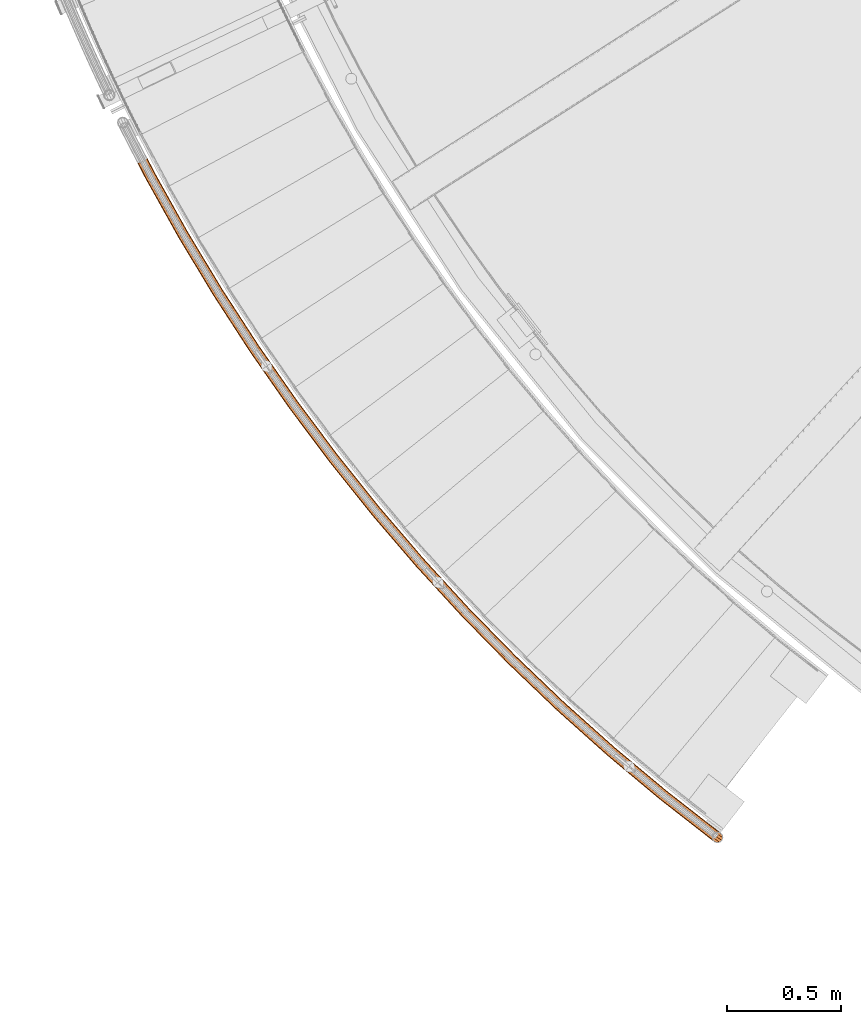
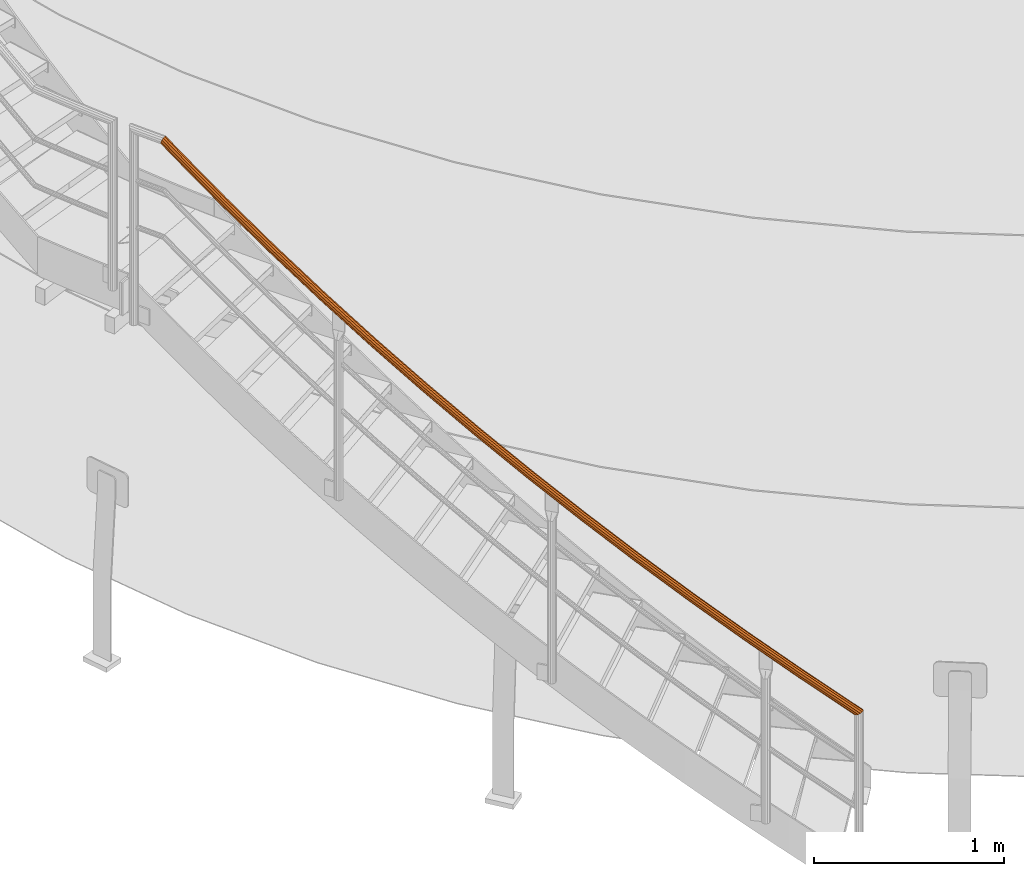
# One storey, part 5 of 126: 1 proxy.
"""IFC2X3 building model written with IfcOpenShell, lengths in millimetres."""

from ifc_helpers import new_model, si_unit, origin, origin_with_axes, place, context, project, spatial, faceted_brep, material, element, save


model = new_model("IFC2X3")

# Units and contexts
context_of_model_1 = context(None, 3, precision=0.1, world=origin())
context_of_model_2 = context(None, 3, precision=0.1, world=origin())
ifc_project = project(units=[si_unit("LENGTHUNIT", "METRE", prefix="MILLI"), si_unit("AREAUNIT", "SQUARE_METRE", prefix="CENTI"), si_unit("VOLUMEUNIT", "CUBIC_METRE", prefix="CENTI"), si_unit("MASSUNIT", "GRAM", prefix="KILO")], contexts=[context_of_model_1, context_of_model_2])

# Site, building, storey
site_placement = place(None, origin_with_axes())
site = spatial("IfcSite", under=ifc_project, at=site_placement, CompositionType="ELEMENT")
building_placement = place(site_placement, origin_with_axes())
building = spatial("IfcBuilding", under=site, at=building_placement, CompositionType="ELEMENT")
storey_placement = place(building_placement, origin_with_axes())
storey = spatial("IfcBuildingStorey", under=building, at=storey_placement, CompositionType="ELEMENT")

# Proxy
ifc_material = material(Name="S235JRG2")
proxy_placement = place(storey_placement, origin_with_axes())
element("IfcBuildingElementProxy", 1, at=proxy_placement, inside=storey, material=ifc_material, Name="HANDLAUF", context=context_of_model_2, shape_type="Brep", body=[
    faceted_brep([(2674.3558, 922.9997, 1115.3389), (2665.639, 914.408, 1112.789), (2681.7253, 902.7135, 1098.7718), (2691.5754, 910.4813, 1100.3342), (2656.2421, 910.3109, 1105.6336), (2669.3052, 900.8141, 1094.2507), (2648.6828, 911.8062, 1095.7899), (2657.6431, 905.2923, 1087.9822), (2644.9868, 918.4934, 1085.8956), (2649.8637, 914.9479, 1081.646), (2646.1442, 928.5804, 1078.6018), (2648.0516, 927.1938, 1076.9398), (2651.8451, 939.3647, 1075.863), (2652.6923, 938.7488, 1075.1247), (2660.5618, 947.9564, 1078.4128), (2662.5423, 946.5166, 1076.6871), (2669.9588, 952.0535, 1085.5683), (2674.9624, 948.4159, 1081.2082), (2677.518, 950.5581, 1095.4119), (2686.6246, 943.9378, 1087.4767), (2681.2141, 943.871, 1105.3062), (2694.4039, 934.2822, 1093.8129), (2680.0566, 933.7839, 1112.6), (2696.2161, 922.0362, 1098.5191), (2673.1906, 923.8467, 1113.2956), (2678.3013, 933.5146, 1110.8403), (2693.7231, 922.3032, 1097.4022), (2689.5628, 911.9444, 1099.0293), (2679.339, 942.5575, 1104.3015), (2692.0985, 933.2814, 1093.1832), (2676.0255, 948.5523, 1095.4315), (2685.1245, 941.9375, 1087.5029), (2669.2488, 949.8929, 1086.6068), (2674.6696, 945.952, 1081.8833), (2660.8246, 946.2199, 1080.1922), (2663.5352, 944.2493, 1077.8302), (2653.0103, 938.5176, 1077.9062), (2654.7049, 937.2857, 1076.4296), (2647.8995, 928.8498, 1080.3616), (2650.5446, 926.9269, 1078.0568), (2646.8619, 919.8069, 1086.9003), (2652.1691, 915.9486, 1082.2757), (2650.1753, 913.812, 1095.7704), (2659.1432, 907.2925, 1087.956), (2656.9521, 912.4715, 1104.595), (2669.5981, 903.278, 1093.5756), (2665.3762, 916.1444, 1111.0097), (2680.7324, 904.9807, 1097.6287), (2441.9465, 1104.063, 1322.9856), (2432.949, 1095.7658, 1320.4357), (2423.4211, 1091.9834, 1313.2801), (2415.9158, 1093.7294, 1303.4363), (2412.4441, 1100.5357, 1293.5421), (2413.9362, 1110.5786, 1286.2485), (2419.9921, 1121.1671, 1283.5097), (2428.9893, 1129.4641, 1286.0595), (2438.517, 1133.2466, 1293.2148), (2446.0224, 1131.501, 1303.0583), (2449.4944, 1124.6949, 1312.9527), (2448.0025, 1114.6519, 1320.2467), (2440.8101, 1104.9483, 1320.9424), (2446.2392, 1114.441, 1318.4869), (2447.5767, 1123.4443, 1311.9481), (2444.4641, 1129.5459, 1303.078), (2437.7357, 1131.1108, 1294.2534), (2429.1942, 1127.7199, 1287.8388), (2421.1285, 1120.2818, 1285.553), (2415.6994, 1110.7894, 1288.0083), (2414.3619, 1101.7862, 1294.5468), (2417.4742, 1095.6844, 1303.4168), (2424.2025, 1094.1192, 1312.2415), (2432.7441, 1097.51, 1318.6564), (2215.6828, 1292.7499, 1530.6324), (2206.4145, 1284.7563, 1528.0824), (2196.7662, 1281.2927, 1520.9268), (2189.3231, 1283.2871, 1511.0831), (2186.0795, 1290.205, 1501.1888), (2187.9045, 1300.1928, 1493.8952), (2194.3089, 1310.5741, 1491.1565), (2203.5768, 1318.5676, 1493.7063), (2213.225, 1322.0313, 1500.8615), (2220.6683, 1320.0373, 1510.7051), (2223.9121, 1313.1195, 1520.5995), (2222.0874, 1303.1316, 1527.8934), (2214.5765, 1293.6725, 1528.5891), (2220.318, 1302.9795, 1526.1337), (2221.9539, 1311.9334, 1519.5948), (2219.0459, 1318.135, 1510.7247), (2212.3731, 1319.9227, 1501.9001), (2203.7238, 1316.8175, 1495.4856), (2195.4152, 1309.6515, 1493.1997), (2189.6738, 1300.3448, 1495.655), (2188.0377, 1291.391, 1502.1936), (2190.9455, 1285.1892, 1511.0636), (2197.6181, 1283.4013, 1519.8883), (2206.2677, 1286.5064, 1526.3031), (1995.8146, 1488.852, 1738.2791), (1986.2858, 1481.1707, 1735.7291), (1976.5277, 1478.0297, 1728.5736), (1969.155, 1480.2703, 1718.7298), (1966.1431, 1487.2923, 1708.8356), (1968.299, 1497.2138, 1701.542), (1975.0449, 1507.3766, 1698.8032), (1984.5734, 1515.0576, 1701.353), (1994.3313, 1518.1989, 1708.5083), (2001.7042, 1515.9585, 1718.3518), (2004.7164, 1508.9368, 1728.2462), (2002.5607, 1499.0151, 1735.5402), (1994.7396, 1489.8108, 1736.2359), (2000.7873, 1498.9218, 1733.7804), (2002.7198, 1507.8164, 1727.2416), (2000.0195, 1514.1113, 1718.3715), (1993.4098, 1516.1197, 1709.5469), (1984.662, 1513.3037, 1703.1323), (1976.12, 1506.4178, 1700.8465), (1970.0724, 1497.307, 1703.3017), (1968.1397, 1488.4125, 1709.8403), (1970.8398, 1482.1175, 1718.7103), (1977.4493, 1480.1088, 1727.535), (1986.1972, 1482.9247, 1733.9499), (1782.5849, 1692.1525, 1945.9259), (1772.8061, 1684.7921, 1943.3759), (1762.949, 1681.9771, 1936.2203), (1755.6548, 1684.4615, 1926.3765), (1752.8779, 1691.5797, 1916.4823), (1755.3624, 1701.4241, 1909.1887), (1762.4423, 1711.3571, 1906.4499), (1772.2207, 1718.7172, 1908.9998), (1782.0777, 1721.5324, 1916.155), (1789.372, 1719.0483, 1925.9986), (1792.1492, 1711.9304, 1935.893), (1789.665, 1702.0858, 1943.1869), (1781.5423, 1693.1465, 1943.8826), (1787.8894, 1702.0515, 1941.4272), (1790.1165, 1710.877, 1934.8883), (1787.6268, 1717.2581, 1926.0182), (1781.0876, 1719.4851, 1917.1936), (1772.251, 1716.9613, 1910.7791), (1763.4849, 1710.3631, 1908.4932), (1757.1378, 1701.4583, 1910.9485), (1754.9106, 1692.633, 1917.4871), (1757.4, 1686.2517, 1926.3571), (1763.9391, 1684.0245, 1935.1818), (1772.7758, 1686.5481, 1941.5966), (1576.2291, 1902.4269, 2153.5726), (1566.2111, 1895.3956, 2151.0226), (1556.2659, 1892.9097, 2143.867), (1549.0583, 1895.6352, 2134.0233), (1546.5196, 1902.8416, 2124.1291), (1549.3298, 1912.5981, 2116.8355), (1556.7359, 1922.2903, 2114.0967), (1566.7535, 1929.3214, 2116.6465), (1576.6986, 1931.8075, 2123.8018), (1583.9063, 1929.0823, 2133.6453), (1586.4454, 1921.876, 2143.5397), (1583.6354, 1912.1194, 2150.8336), (1575.2202, 1903.455, 2151.5293), (1581.8597, 1912.1442, 2149.0739), (1584.3789, 1920.8907, 2142.5351), (1582.1026, 1927.3511, 2133.665), (1575.641, 1929.7941, 2124.8404), (1566.7255, 1927.5654, 2118.4258), (1557.7449, 1921.2622, 2116.14), (1551.1054, 1912.5733, 2118.5952), (1548.5861, 1903.8268, 2125.1338), (1550.8621, 1897.3663, 2134.0038), (1557.3236, 1894.923, 2142.8285), (1566.2393, 1897.1516, 2149.2434), (1376.9753, 2119.4429, 2361.2194), (1366.7292, 2112.7484, 2358.6694), (1356.7069, 2110.5943, 2351.5138), (1349.5938, 2113.5579, 2341.67), (1347.296, 2120.8447, 2331.7758), (1350.4289, 2130.5024, 2324.4822), (1358.153, 2139.9431, 2321.7434), (1368.3987, 2146.6374, 2324.2933), (1378.4209, 2148.7916, 2331.4485), (1385.5341, 2145.8285, 2341.2921), (1387.8324, 2138.5418, 2351.1864), (1384.6996, 2128.8839, 2358.4804), (1376.0011, 2120.5039, 2359.1761), (1382.9258, 2128.9677, 2356.7207), (1385.7342, 2137.6257, 2350.1818), (1383.6739, 2144.1581, 2341.3117), (1377.2971, 2146.8146, 2332.4871), (1368.3124, 2144.8834, 2326.0726), (1359.1272, 2138.882, 2323.7867), (1352.2027, 2130.4186, 2326.242), (1349.3941, 2121.7607, 2332.7806), (1351.4541, 2115.2281, 2341.6505), (1357.8309, 2112.5714, 2350.4753), (1366.8157, 2114.5025, 2356.8901), (1185.0436, 2342.9607, 2568.8661), (1174.5807, 2336.6104, 2566.3161), (1164.4923, 2334.7907, 2559.1605), (1157.4817, 2337.9889, 2549.3168), (1155.4273, 2345.3481, 2539.4226), (1158.8794, 2354.8963, 2532.129), (1166.913, 2364.0752, 2529.3902), (1177.3755, 2370.4253, 2531.94), (1187.4638, 2372.2452, 2539.0952), (1194.4746, 2369.0473, 2548.9388), (1196.5294, 2361.6883, 2558.8332), (1193.0774, 2352.1399, 2566.1271), (1184.1052, 2344.0536, 2566.8228), (1191.3073, 2352.2825, 2564.3674), (1194.4019, 2360.8424, 2557.8286), (1192.5599, 2367.4397, 2548.9584), (1186.2748, 2370.3066, 2540.1339), (1177.2309, 2368.6751, 2533.7193), (1167.8514, 2362.9823, 2531.4335), (1160.6494, 2354.7536, 2533.8887), (1157.5547, 2346.1938, 2540.4273), (1159.3965, 2339.5965, 2549.2973), (1165.6814, 2336.7293, 2558.122), (1174.7254, 2338.3607, 2564.5368), (1000.646, 2572.7335, 2776.5129), (989.9778, 2566.7345, 2773.9629), (979.8346, 2565.2509, 2766.8073), (972.9341, 2568.6804, 2756.9635), (971.1253, 2576.1038, 2747.0693), (974.8929, 2585.532, 2739.7757), (983.2271, 2594.4388, 2737.0369), (993.8949, 2600.4377, 2739.5867), (1004.038, 2601.9214, 2746.742), (1010.9387, 2598.4923, 2756.5856), (1012.7478, 2591.069, 2766.4799), (1008.9804, 2581.6406, 2773.7739), (999.7444, 2573.857, 2774.4696), (1007.216, 2581.842, 2772.0142), (1010.5934, 2590.2944, 2765.4753), (1008.9716, 2596.9492, 2756.6052), (1002.7853, 2600.0234, 2747.7806), (993.6922, 2598.6933, 2741.3661), (984.1287, 2593.3154, 2739.0802), (976.6572, 2585.3306, 2741.5355), (973.2797, 2576.8784, 2748.0741), (974.9012, 2570.2234, 2756.944), (981.0874, 2567.149, 2765.7688), (990.1806, 2568.4789, 2772.1836), (823.9862, 2808.5074, 2984.1596), (813.1246, 2802.8662, 2981.6096), (802.9376, 2801.7206, 2974.454), (796.1549, 2805.3775, 2964.6103), (794.5939, 2812.8569, 2954.7161), (798.6726, 2822.1547, 2947.4225), (807.2982, 2830.7796, 2944.6837), (818.1595, 2836.4207, 2947.2335), (828.3463, 2837.5665, 2954.3887), (835.1292, 2833.9099, 2964.2323), (836.6906, 2826.4306, 2974.1267), (832.612, 2817.1326, 2981.4206), (823.1225, 2809.6602, 2982.1163), (830.8553, 2817.3925, 2979.6609), (834.5117, 2825.728, 2973.1221), (833.112, 2832.433, 2964.2519), (827.0312, 2835.7111, 2955.4274), (817.8989, 2834.6839, 2949.0128), (808.162, 2829.6268, 2946.7269), (800.4293, 2821.8947, 2949.1822), (796.7728, 2813.5594, 2955.7208), (798.1722, 2806.8543, 2964.5908), (804.2528, 2803.576, 2973.4155), (813.3852, 2804.603, 2979.8303), (655.2594, 3050.0219, 3191.8063), (644.2163, 3044.7448, 3189.2564), (633.9969, 3043.9384, 3182.1008), (627.3394, 3047.8187, 3172.257), (626.0278, 3055.3458, 3162.3628), (630.4133, 3064.503, 3155.0692), (639.3208, 3072.8364, 3152.3304), (650.3635, 3078.1135, 3154.8802), (660.5828, 3078.9201, 3162.0355), (667.2405, 3075.0401, 3171.8791), (668.5524, 3067.513, 3181.7734), (664.1671, 3058.3557, 3189.0674), (654.4344, 3051.2028, 3189.7631), (662.42, 3058.6739, 3187.3077), (666.3514, 3066.8832, 3180.7688), (665.1752, 3073.6311, 3171.8987), (659.2068, 3077.1094, 3163.0741), (650.0454, 3076.3863, 3156.6596), (640.1458, 3071.6556, 3154.3737), (632.1604, 3064.1848, 3156.829), (628.2289, 3055.9756, 3163.3676), (629.4047, 3049.2276, 3172.2375), (635.373, 3045.749, 3181.0623), (644.5345, 3046.472, 3187.4771), (494.652, 3297.0103, 3399.4531), (483.4396, 3292.1031, 3396.9031), (473.199, 3291.6367, 3389.7475), (466.6742, 3295.7361, 3379.9038), (465.6134, 3303.3027, 3370.0096), (470.3008, 3312.309, 3362.716), (479.4803, 3320.3419, 3359.9772), (490.6923, 3325.249, 3362.527), (500.9328, 3325.7156, 3369.6822), (507.4578, 3321.6165, 3379.5258), (508.5189, 3314.05, 3389.4202), (503.8317, 3305.0435, 3396.7141), (493.8667, 3298.218, 3397.4098), (502.0961, 3305.4195, 3394.9544), (506.2981, 3313.4937, 3388.4155), (505.3469, 3320.2769, 3379.5454), (499.4973, 3323.9517, 3370.7209), (490.317, 3323.5334, 3364.3063), (480.2656, 3319.1343, 3362.0204), (472.0364, 3311.9329, 3364.4757), (467.8342, 3303.859, 3371.0143), (468.7852, 3297.0756, 3379.8843), (474.6345, 3293.4006, 3388.709), (483.815, 3293.8187, 3395.1238), (342.3413, 3549.1997, 3607.0998), (330.972, 3544.6678, 3604.5499), (320.7216, 3544.542, 3597.3943), (314.3366, 3548.856, 3587.5505), (313.5279, 3556.4536, 3577.6563), (318.512, 3565.2992, 3570.3627), (327.9534, 3573.0226, 3567.6239), (339.3223, 3577.5544, 3570.1737), (349.5726, 3577.6804, 3577.329), (355.9578, 3573.3667, 3587.1725), (356.7669, 3565.7691, 3597.0669), (351.7829, 3556.9233, 3604.3609), (341.5966, 3550.4327, 3605.0566), (350.0608, 3557.3568, 3602.6011), (354.5288, 3565.2869, 3596.0623), (353.8035, 3572.098, 3587.1922), (348.0793, 3575.9651, 3578.3676), (338.8901, 3575.8522, 3571.953), (328.6981, 3571.7895, 3569.6672), (320.2341, 3564.8656, 3572.1225), (315.766, 3556.9358, 3578.661), (316.491, 3550.1246, 3587.531), (322.2149, 3546.2572, 3596.3557), (331.4042, 3546.37, 3602.7706), (198.4957, 3806.3114, 3814.7466), (186.9821, 3802.1599, 3812.1966), (176.7331, 3802.3748, 3805.041), (170.4951, 3806.8986, 3795.1973), (169.9393, 3814.5189, 3785.3031), (175.2146, 3823.194, 3778.0095), (184.9074, 3830.5993, 3775.2707), (196.4206, 3834.7508, 3777.8205), (206.6695, 3834.5361, 3784.9757), (212.9078, 3830.0126, 3794.8193), (213.4639, 3822.3923, 3804.7137), (208.1887, 3813.717, 3812.0076), (197.7923, 3807.5686, 3812.7033), (206.482, 3814.2075, 3810.2479), (211.2111, 3821.9847, 3803.709), (210.7125, 3828.8162, 3794.8389), (205.12, 3832.8714, 3786.0144), (195.9321, 3833.0639, 3779.5998), (185.6107, 3829.3422, 3777.3139), (176.9213, 3822.7034, 3779.7692), (172.1921, 3814.9264, 3786.3078), (172.6904, 3808.0949, 3795.1778), (178.2827, 3804.0395, 3804.0025), (187.4706, 3803.8468, 3810.4173), (161.6411, 3877.6512, 3871.3405), (150.334, 3873.1351, 3868.4187), (141.0347, 3871.6072, 3859.8114), (136.2318, 3873.4752, 3847.8256), (137.2098, 3878.2383, 3835.67), (143.7073, 3884.6218, 3826.5984), (153.9864, 3890.917, 3823.0408), (165.2954, 3895.4372, 3825.9533), (174.6033, 3896.9699, 3834.559), (179.4129, 3895.1025, 3846.5525), (178.433, 3890.3352, 3858.7173), (171.927, 3883.9469, 3867.7906), (161.2467, 3878.3387, 3868.8405), (170.4674, 3883.9827, 3865.6577), (176.2996, 3889.7094, 3857.5238), (177.1779, 3893.983, 3846.6186), (172.8665, 3895.6571, 3835.8671), (164.5225, 3894.2833, 3828.1522), (154.3844, 3890.2312, 3825.5407), (145.169, 3884.5877, 3828.7297), (139.3437, 3878.8648, 3836.8623), (138.4669, 3874.5946, 3847.76), (142.7729, 3872.92, 3858.5054), (151.11, 3874.2899, 3866.2216)], [[[0, 1, 2, 3]], [[1, 4, 5, 2]], [[4, 6, 7, 5]], [[6, 8, 9, 7]], [[8, 10, 11, 9]], [[10, 12, 13, 11]], [[12, 14, 15, 13]], [[14, 16, 17, 15]], [[16, 18, 19, 17]], [[18, 20, 21, 19]], [[20, 22, 23, 21]], [[0, 3, 23, 22]], [[24, 25, 26, 27]], [[25, 28, 29, 26]], [[28, 30, 31, 29]], [[30, 32, 33, 31]], [[32, 34, 35, 33]], [[34, 36, 37, 35]], [[36, 38, 39, 37]], [[38, 40, 41, 39]], [[40, 42, 43, 41]], [[42, 44, 45, 43]], [[44, 46, 47, 45]], [[24, 27, 47, 46]], [[0, 48, 49, 1]], [[1, 49, 50, 4]], [[4, 50, 51, 6]], [[6, 51, 52, 8]], [[8, 52, 53, 10]], [[10, 53, 54, 12]], [[12, 54, 55, 14]], [[14, 55, 56, 16]], [[16, 56, 57, 18]], [[18, 57, 58, 20]], [[20, 58, 59, 22]], [[22, 59, 48, 0]], [[24, 60, 61, 25]], [[25, 61, 62, 28]], [[28, 62, 63, 30]], [[30, 63, 64, 32]], [[32, 64, 65, 34]], [[34, 65, 66, 36]], [[36, 66, 67, 38]], [[38, 67, 68, 40]], [[40, 68, 69, 42]], [[42, 69, 70, 44]], [[44, 70, 71, 46]], [[46, 71, 60, 24]], [[48, 72, 73, 49]], [[49, 73, 74, 50]], [[50, 74, 75, 51]], [[51, 75, 76, 52]], [[52, 76, 77, 53]], [[53, 77, 78, 54]], [[54, 78, 79, 55]], [[55, 79, 80, 56]], [[56, 80, 81, 57]], [[57, 81, 82, 58]], [[58, 82, 83, 59]], [[59, 83, 72, 48]], [[60, 84, 85, 61]], [[61, 85, 86, 62]], [[62, 86, 87, 63]], [[63, 87, 88, 64]], [[64, 88, 89, 65]], [[65, 89, 90, 66]], [[66, 90, 91, 67]], [[67, 91, 92, 68]], [[68, 92, 93, 69]], [[69, 93, 94, 70]], [[70, 94, 95, 71]], [[71, 95, 84, 60]], [[72, 96, 97, 73]], [[73, 97, 98, 74]], [[74, 98, 99, 75]], [[75, 99, 100, 76]], [[76, 100, 101, 77]], [[77, 101, 102, 78]], [[78, 102, 103, 79]], [[79, 103, 104, 80]], [[80, 104, 105, 81]], [[81, 105, 106, 82]], [[82, 106, 107, 83]], [[83, 107, 96, 72]], [[84, 108, 109, 85]], [[85, 109, 110, 86]], [[86, 110, 111, 87]], [[87, 111, 112, 88]], [[88, 112, 113, 89]], [[89, 113, 114, 90]], [[90, 114, 115, 91]], [[91, 115, 116, 92]], [[92, 116, 117, 93]], [[93, 117, 118, 94]], [[94, 118, 119, 95]], [[95, 119, 108, 84]], [[96, 120, 121, 97]], [[97, 121, 122, 98]], [[98, 122, 123, 99]], [[99, 123, 124, 100]], [[100, 124, 125, 101]], [[101, 125, 126, 102]], [[102, 126, 127, 103]], [[103, 127, 128, 104]], [[104, 128, 129, 105]], [[105, 129, 130, 106]], [[106, 130, 131, 107]], [[107, 131, 120, 96]], [[108, 132, 133, 109]], [[109, 133, 134, 110]], [[110, 134, 135, 111]], [[111, 135, 136, 112]], [[112, 136, 137, 113]], [[113, 137, 138, 114]], [[114, 138, 139, 115]], [[115, 139, 140, 116]], [[116, 140, 141, 117]], [[117, 141, 142, 118]], [[118, 142, 143, 119]], [[119, 143, 132, 108]], [[120, 144, 145, 121]], [[121, 145, 146, 122]], [[122, 146, 147, 123]], [[123, 147, 148, 124]], [[124, 148, 149, 125]], [[125, 149, 150, 126]], [[126, 150, 151, 127]], [[127, 151, 152, 128]], [[128, 152, 153, 129]], [[129, 153, 154, 130]], [[130, 154, 155, 131]], [[131, 155, 144, 120]], [[132, 156, 157, 133]], [[133, 157, 158, 134]], [[134, 158, 159, 135]], [[135, 159, 160, 136]], [[136, 160, 161, 137]], [[137, 161, 162, 138]], [[138, 162, 163, 139]], [[139, 163, 164, 140]], [[140, 164, 165, 141]], [[141, 165, 166, 142]], [[142, 166, 167, 143]], [[143, 167, 156, 132]], [[144, 168, 169, 145]], [[145, 169, 170, 146]], [[146, 170, 171, 147]], [[147, 171, 172, 148]], [[148, 172, 173, 149]], [[149, 173, 174, 150]], [[150, 174, 175, 151]], [[151, 175, 176, 152]], [[152, 176, 177, 153]], [[153, 177, 178, 154]], [[154, 178, 179, 155]], [[155, 179, 168, 144]], [[156, 180, 181, 157]], [[157, 181, 182, 158]], [[158, 182, 183, 159]], [[159, 183, 184, 160]], [[160, 184, 185, 161]], [[161, 185, 186, 162]], [[162, 186, 187, 163]], [[163, 187, 188, 164]], [[164, 188, 189, 165]], [[165, 189, 190, 166]], [[166, 190, 191, 167]], [[167, 191, 180, 156]], [[168, 192, 193, 169]], [[169, 193, 194, 170]], [[170, 194, 195, 171]], [[171, 195, 196, 172]], [[172, 196, 197, 173]], [[173, 197, 198, 174]], [[174, 198, 199, 175]], [[175, 199, 200, 176]], [[176, 200, 201, 177]], [[177, 201, 202, 178]], [[178, 202, 203, 179]], [[179, 203, 192, 168]], [[180, 204, 205, 181]], [[181, 205, 206, 182]], [[182, 206, 207, 183]], [[183, 207, 208, 184]], [[184, 208, 209, 185]], [[185, 209, 210, 186]], [[186, 210, 211, 187]], [[187, 211, 212, 188]], [[188, 212, 213, 189]], [[189, 213, 214, 190]], [[190, 214, 215, 191]], [[191, 215, 204, 180]], [[192, 216, 217, 193]], [[193, 217, 218, 194]], [[194, 218, 219, 195]], [[195, 219, 220, 196]], [[196, 220, 221, 197]], [[197, 221, 222, 198]], [[198, 222, 223, 199]], [[199, 223, 224, 200]], [[200, 224, 225, 201]], [[201, 225, 226, 202]], [[202, 226, 227, 203]], [[203, 227, 216, 192]], [[204, 228, 229, 205]], [[205, 229, 230, 206]], [[206, 230, 231, 207]], [[207, 231, 232, 208]], [[208, 232, 233, 209]], [[209, 233, 234, 210]], [[210, 234, 235, 211]], [[211, 235, 236, 212]], [[212, 236, 237, 213]], [[213, 237, 238, 214]], [[214, 238, 239, 215]], [[215, 239, 228, 204]], [[216, 240, 241, 217]], [[217, 241, 242, 218]], [[218, 242, 243, 219]], [[219, 243, 244, 220]], [[220, 244, 245, 221]], [[221, 245, 246, 222]], [[222, 246, 247, 223]], [[223, 247, 248, 224]], [[224, 248, 249, 225]], [[225, 249, 250, 226]], [[226, 250, 251, 227]], [[227, 251, 240, 216]], [[228, 252, 253, 229]], [[229, 253, 254, 230]], [[230, 254, 255, 231]], [[231, 255, 256, 232]], [[232, 256, 257, 233]], [[233, 257, 258, 234]], [[234, 258, 259, 235]], [[235, 259, 260, 236]], [[236, 260, 261, 237]], [[237, 261, 262, 238]], [[238, 262, 263, 239]], [[239, 263, 252, 228]], [[240, 264, 265, 241]], [[241, 265, 266, 242]], [[242, 266, 267, 243]], [[243, 267, 268, 244]], [[244, 268, 269, 245]], [[245, 269, 270, 246]], [[246, 270, 271, 247]], [[247, 271, 272, 248]], [[248, 272, 273, 249]], [[249, 273, 274, 250]], [[250, 274, 275, 251]], [[251, 275, 264, 240]], [[252, 276, 277, 253]], [[253, 277, 278, 254]], [[254, 278, 279, 255]], [[255, 279, 280, 256]], [[256, 280, 281, 257]], [[257, 281, 282, 258]], [[258, 282, 283, 259]], [[259, 283, 284, 260]], [[260, 284, 285, 261]], [[261, 285, 286, 262]], [[262, 286, 287, 263]], [[263, 287, 276, 252]], [[264, 288, 289, 265]], [[265, 289, 290, 266]], [[266, 290, 291, 267]], [[267, 291, 292, 268]], [[268, 292, 293, 269]], [[269, 293, 294, 270]], [[270, 294, 295, 271]], [[271, 295, 296, 272]], [[272, 296, 297, 273]], [[273, 297, 298, 274]], [[274, 298, 299, 275]], [[275, 299, 288, 264]], [[276, 300, 301, 277]], [[277, 301, 302, 278]], [[278, 302, 303, 279]], [[279, 303, 304, 280]], [[280, 304, 305, 281]], [[281, 305, 306, 282]], [[282, 306, 307, 283]], [[283, 307, 308, 284]], [[284, 308, 309, 285]], [[285, 309, 310, 286]], [[286, 310, 311, 287]], [[287, 311, 300, 276]], [[288, 312, 313, 289]], [[289, 313, 314, 290]], [[290, 314, 315, 291]], [[291, 315, 316, 292]], [[292, 316, 317, 293]], [[293, 317, 318, 294]], [[294, 318, 319, 295]], [[295, 319, 320, 296]], [[296, 320, 321, 297]], [[297, 321, 322, 298]], [[298, 322, 323, 299]], [[299, 323, 312, 288]], [[300, 324, 325, 301]], [[301, 325, 326, 302]], [[302, 326, 327, 303]], [[303, 327, 328, 304]], [[304, 328, 329, 305]], [[305, 329, 330, 306]], [[306, 330, 331, 307]], [[307, 331, 332, 308]], [[308, 332, 333, 309]], [[309, 333, 334, 310]], [[310, 334, 335, 311]], [[311, 335, 324, 300]], [[312, 336, 337, 313]], [[313, 337, 338, 314]], [[314, 338, 339, 315]], [[315, 339, 340, 316]], [[316, 340, 341, 317]], [[317, 341, 342, 318]], [[318, 342, 343, 319]], [[319, 343, 344, 320]], [[320, 344, 345, 321]], [[321, 345, 346, 322]], [[322, 346, 347, 323]], [[323, 347, 336, 312]], [[324, 348, 349, 325]], [[325, 349, 350, 326]], [[326, 350, 351, 327]], [[327, 351, 352, 328]], [[328, 352, 353, 329]], [[329, 353, 354, 330]], [[330, 354, 355, 331]], [[331, 355, 356, 332]], [[332, 356, 357, 333]], [[333, 357, 358, 334]], [[334, 358, 359, 335]], [[335, 359, 348, 324]], [[336, 360, 361, 337]], [[337, 361, 362, 338]], [[338, 362, 363, 339]], [[339, 363, 364, 340]], [[340, 364, 365, 341]], [[341, 365, 366, 342]], [[342, 366, 367, 343]], [[343, 367, 368, 344]], [[344, 368, 369, 345]], [[345, 369, 370, 346]], [[346, 370, 371, 347]], [[336, 347, 371, 360]], [[348, 372, 373, 349]], [[349, 373, 374, 350]], [[350, 374, 375, 351]], [[351, 375, 376, 352]], [[352, 376, 377, 353]], [[353, 377, 378, 354]], [[354, 378, 379, 355]], [[355, 379, 380, 356]], [[356, 380, 381, 357]], [[357, 381, 382, 358]], [[358, 382, 383, 359]], [[348, 359, 383, 372]], [[360, 371, 370, 369, 368, 367, 366, 365, 364, 363, 362, 361], [372, 383, 382, 381, 380, 379, 378, 377, 376, 375, 374, 373]], [[5, 7, 9, 11, 13, 15, 17, 19, 21, 23, 3, 2], [26, 29, 31, 33, 35, 37, 39, 41, 43, 45, 47, 27]]]),
])

save(model, "model.ifc")
